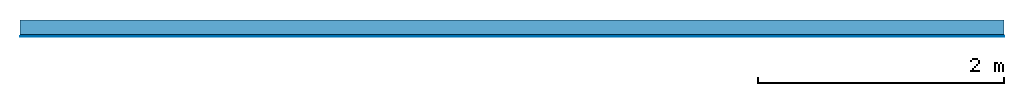
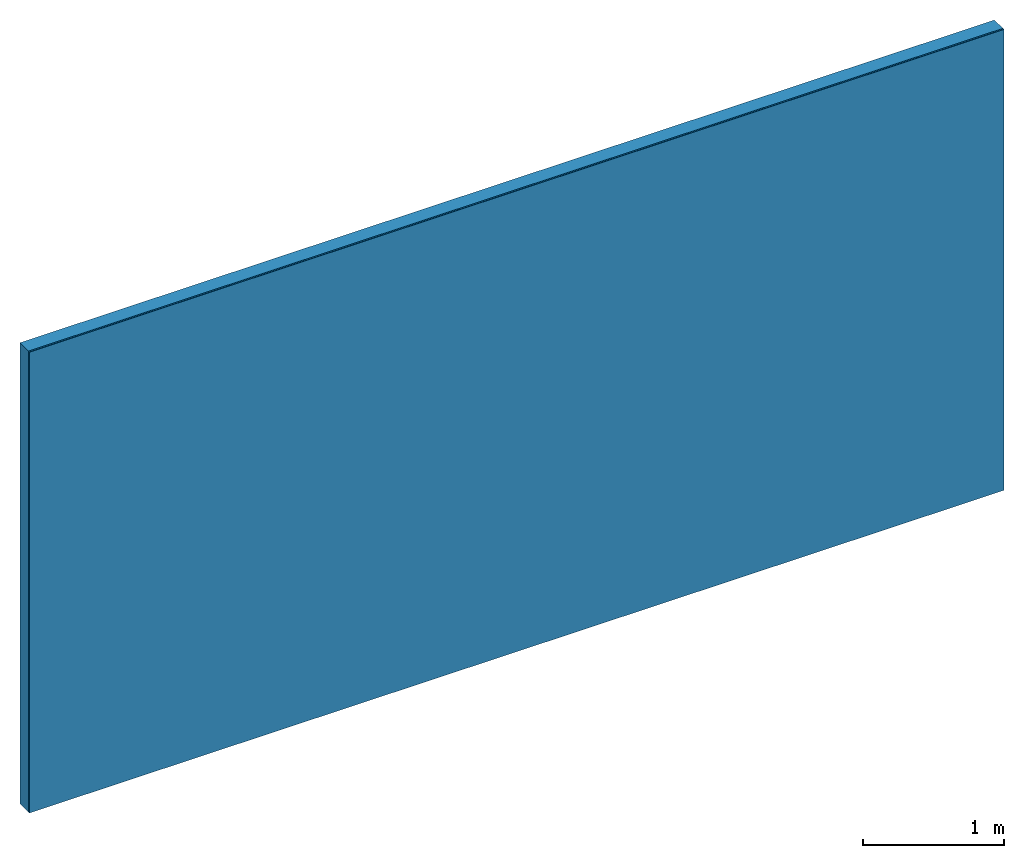
# One storey: 2 plates, 1 member, 1 element without a shape of its own.
"""IFC4 building model written with IfcOpenShell, lengths in metres."""

import ifcopenshell
import ifcopenshell.guid

model = None  # the IFC model being written
_history = None  # IfcOwnerHistory: only IFC2X3 demands one
_inside = {}  # id of a spatial element -> (the spatial element, [elements in it])
_under = {}  # id of a project, library or spatial element -> (it, [spatial elements below it])
_declared = {}  # id of a project -> (the project, [libraries it declares])
_typed = {}  # id of a type object -> (the type object, [elements of that type])
_made_of = {}  # id of a material, layer set ... -> (it, [elements and type objects made of it])


def new_model(schema):
    """Start an empty IFC model of exactly this schema.

    Asked for "IFC4X3", IfcOpenShell would pick the latest addendum, in which some entities
    have other attributes; the version numbers below select the first issue.
    IFC2X3 requires an IfcOwnerHistory on every rooted entity: one is made here for all.
    """
    global model, _history
    if schema == "IFC4X3":
        model = ifcopenshell.file(schema_version=(4, 3, 0, 0))
    else:
        model = ifcopenshell.file(schema=schema)
    _inside.clear()
    _under.clear()
    _declared.clear()
    _typed.clear()
    _made_of.clear()
    _history = None
    if model.schema == "IFC2X3":
        org = make("IfcOrganization", Name="unknown")
        user = make(
            "IfcPersonAndOrganization",
            ThePerson=make("IfcPerson", FamilyName="unknown"),
            TheOrganization=org,
        )
        app = make(
            "IfcApplication",
            ApplicationDeveloper=org,
            Version="unknown",
            ApplicationFullName="unknown",
            ApplicationIdentifier="unknown",
        )
        _history = make(
            "IfcOwnerHistory",
            OwningUser=user,
            OwningApplication=app,
            ChangeAction="ADDED",
            CreationDate=0,
        )
    return model


def make(cls, **values):
    """One entity of the class cls with the attributes given. An attribute that is None is left unset."""
    return model.create_entity(
        cls, **{name: value for name, value in values.items() if value is not None}
    )


def rooted(cls, **values):
    """An entity with a GlobalId (a new one), such as an element, a storey or a relation."""
    return make(cls, GlobalId=ifcopenshell.guid.new(), OwnerHistory=_history, **values)


def si_unit(unit_type, name, prefix=None):
    """IfcSIUnit, for example si_unit("LENGTHUNIT", "METRE", prefix="MILLI")."""
    return make("IfcSIUnit", UnitType=unit_type, Prefix=prefix, Name=name)


def derived_unit(unit_type, elements):
    """IfcDerivedUnit: a product of units, each with its exponent."""
    return make(
        "IfcDerivedUnit",
        Elements=[
            make("IfcDerivedUnitElement", Unit=unit, Exponent=power)
            for unit, power in elements
        ],
        UnitType=unit_type,
    )


def assignment(units):
    """IfcUnitAssignment: the units of a project."""
    return None if units is None else make("IfcUnitAssignment", Units=units)


def point(xyz):
    """IfcCartesianPoint."""
    return None if xyz is None else make("IfcCartesianPoint", Coordinates=xyz)


def direction(xyz):
    """IfcDirection."""
    return None if xyz is None else make("IfcDirection", DirectionRatios=xyz)


def frame(location, z_axis=None, x_axis=None):
    """IfcAxis2Placement3D, a coordinate frame: its origin and axes. An axis left out is left unset."""
    return make(
        "IfcAxis2Placement3D",
        Location=point(location),
        Axis=direction(z_axis),
        RefDirection=direction(x_axis),
    )


def frame_2d(location, x_axis=None):
    """IfcAxis2Placement2D, a coordinate frame in the plane: its origin and x axis."""
    return make(
        "IfcAxis2Placement2D", Location=point(location), RefDirection=direction(x_axis)
    )


def origin():
    """The frame at (0, 0, 0) with its axes left unset."""
    return frame((0.0, 0.0, 0.0))


def place(relative_to, where):
    """IfcLocalPlacement: puts the frame where relative to a parent placement (None: the world)."""
    return make(
        "IfcLocalPlacement", PlacementRelTo=relative_to, RelativePlacement=where
    )


def context(
    kind, dimensions, precision=None, world=None, true_north=None, identifier=None
):
    """IfcGeometricRepresentationContext, for example the 3D "Model" context."""
    return make(
        "IfcGeometricRepresentationContext",
        ContextIdentifier=identifier,
        ContextType=kind,
        CoordinateSpaceDimension=dimensions,
        Precision=precision,
        WorldCoordinateSystem=world,
        TrueNorth=true_north,
    )


def project(units=None, contexts=None):
    """IfcProject with its units and contexts."""
    return rooted(
        "IfcProject",
        Name="project",
        RepresentationContexts=contexts,
        UnitsInContext=assignment(units),
    )


def spatial(cls, under=None, at=None, **own):
    """A site, building, storey or space (cls), placed at a placement, below another one or the project."""
    s = rooted(cls, ObjectPlacement=at, **own)
    if under is not None:
        _under.setdefault(under.id(), (under, []))[1].append(s)
    return s


def profile(cls, at=None, kind="AREA", **sizes):
    """A parametric profile (cls). Its sizes go by their IFC names, for example OverallWidth=200.0."""
    return make(cls, ProfileType=kind, Position=at, **sizes)


def rectangle(**sizes):
    """IfcRectangleProfileDef."""
    return profile("IfcRectangleProfileDef", **sizes)


def extrude(swept, where, along, depth):
    """IfcExtrudedAreaSolid: the profile swept, set in the frame where, extruded along a direction by depth."""
    return make(
        "IfcExtrudedAreaSolid",
        SweptArea=swept,
        Position=where,
        ExtrudedDirection=direction(along),
        Depth=depth,
    )


def shape(context_of_items, identifier, shape_type, items):
    """IfcShapeRepresentation: the items that make up one representation, for example the "Body"."""
    return make(
        "IfcShapeRepresentation",
        ContextOfItems=context_of_items,
        RepresentationIdentifier=identifier,
        RepresentationType=shape_type,
        Items=items,
    )


def material(Name=None, Category=None):
    """IfcMaterial."""
    return make("IfcMaterial", Name=Name, Category=Category)


def layer(
    of_material, thickness, ventilated=None, Name=None, Category=None, Priority=None
):
    """IfcMaterialLayer: one layer of a wall or slab, of a material (None: an air gap)."""
    return make(
        "IfcMaterialLayer",
        Material=of_material,
        LayerThickness=thickness,
        IsVentilated=ventilated,
        Name=Name,
        Category=Category,
        Priority=Priority,
    )


def layer_set(layers, Name=None):
    """IfcMaterialLayerSet."""
    return make("IfcMaterialLayerSet", MaterialLayers=layers, LayerSetName=Name)


def made_of(thing, what):
    """Note that an element or type object is made of a material, layer set ...; save() writes the relation."""
    if what is not None:
        _made_of.setdefault(what.id(), (what, []))[1].append(thing)
    return thing


def type_object(cls, material=None, **own):
    """A type object (cls), such as IfcWallType, which elements share."""
    return made_of(rooted(cls, **own), material)


def element(
    cls,
    number,
    at=None,
    inside=None,
    cuts=None,
    type_object=None,
    material=None,
    context=None,
    identifier="Body",
    shape_type=None,
    held_by="IfcProductDefinitionShape",
    body=None,
    shapes=None,
    **own,
):
    """One element of the class cls, such as IfcWall. Its Tag is "e" and its number.

    at: its placement. inside: the storey or other place that contains it. cuts: it is an
    opening in that element (IfcRelVoidsElement). A single representation is given by context,
    identifier, shape_type and body (its items); several are given by shapes. held_by: the class
    of the entity that holds the representations. save() writes the other relations.
    """
    e = rooted(cls, Tag="e%d" % number, ObjectPlacement=at, **own)
    if body is not None:
        shapes = [shape(context, identifier, shape_type, body)]
    if shapes is not None:
        e.Representation = make(held_by, Representations=shapes)
    if inside is not None:
        _inside.setdefault(inside.id(), (inside, []))[1].append(e)
    if cuts is not None:
        rooted(
            "IfcRelVoidsElement", RelatingBuildingElement=cuts, RelatedOpeningElement=e
        )
    if type_object is not None:
        _typed.setdefault(type_object.id(), (type_object, []))[1].append(e)
    return made_of(e, material)


def aggregate(whole, parts):
    """IfcRelAggregates: a whole, such as a stair, and the parts it consists of."""
    return rooted("IfcRelAggregates", RelatingObject=whole, RelatedObjects=parts)


def save(model, path):
    """Write the relations noted so far, then the file.

    IfcRelAggregates (storeys below a building ...), IfcRelContainedInSpatialStructure (elements
    in a storey), IfcRelDefinesByType, IfcRelAssociatesMaterial and IfcRelDeclares: one each for
    every whole, place, type object, material and project.
    """
    for whole, parts in _under.values():
        aggregate(whole, parts)
    for where, things in _inside.values():
        rooted(
            "IfcRelContainedInSpatialStructure",
            RelatedElements=things,
            RelatingStructure=where,
        )
    for kind, things in _typed.values():
        rooted("IfcRelDefinesByType", RelatedObjects=things, RelatingType=kind)
    for what, things in _made_of.values():
        rooted("IfcRelAssociatesMaterial", RelatedObjects=things, RelatingMaterial=what)
    for by, libraries in _declared.values():
        rooted("IfcRelDeclares", RelatingContext=by, RelatedDefinitions=libraries)
    model.write(path)


model = new_model("IFC4")

# Units and contexts
plan_context = context("Plan", 3, precision=1e-05, world=origin(), true_north=direction((0.0, 1.0)))
model_context = context("Model", 3, precision=1e-05, world=origin(), true_north=direction((0.0, 1.0)))
ifc_project = project(units=[si_unit("LENGTHUNIT", "METRE"), derived_unit("SOUNDPRESSUREUNIT", [(si_unit("PRESSUREUNIT", "PASCAL", prefix="MICRO"), 0)]), si_unit("ENERGYUNIT", "JOULE", prefix="MEGA"), si_unit("MASSUNIT", "GRAM", prefix="KILO"), derived_unit("THERMALTRANSMITTANCEUNIT", [(si_unit("POWERUNIT", "WATT"), 1), (si_unit("AREAUNIT", "SQUARE_METRE"), -1), (si_unit("THERMODYNAMICTEMPERATUREUNIT", "KELVIN"), -1)]), derived_unit("AREADENSITYUNIT", [(si_unit("MASSUNIT", "GRAM", prefix="KILO"), 1), (si_unit("AREAUNIT", "SQUARE_METRE"), -1)]), derived_unit("USERDEFINED", [(si_unit("ENERGYUNIT", "JOULE", prefix="MEGA"), 1), (si_unit("AREAUNIT", "SQUARE_METRE"), -1)])], contexts=[plan_context, model_context])

# Site, building, storey
site = spatial("IfcSite", under=ifc_project)
building_placement = place(None, origin())
building = spatial("IfcBuilding", under=site, at=building_placement)
storey_placement = place(building_placement, origin())
storey = spatial("IfcBuildingStorey", under=building, at=storey_placement)

# Wall, member, plates
ifc_layer_1 = layer(None, 0.12, Name="Support")
ifc_material_1 = material(Name="of the art")
ifc_layer_2 = layer(ifc_material_1, 0.0, Name="Bond")
ifc_material_2 = material(Name="Plasterboard type A", Category="03.008")
ifc_layer_3 = layer(ifc_material_2, 0.0125, Name="1st layer")
ifc_material_3 = material(Category="04.001")
ifc_layer_4 = layer(ifc_material_3, 0.003, Name="Surface")
ifc_layer_set = layer_set([ifc_layer_1, ifc_layer_2, ifc_layer_3, ifc_layer_4])
wall_type = type_object("IfcWallType", Name="C0353", PredefinedType="NOTDEFINED", material=ifc_layer_set)
wall_placement = place(None, frame((0.0, 0.0, 0.0), z_axis=(0.0, -1.0, 0.0), x_axis=(1.0, 0.0, 0.0)))
wall = element("IfcWall", 1, at=wall_placement, inside=storey, type_object=wall_type, material=ifc_layer_set, Name="Wall #1")
ifc_material_4 = material(Name="Solid timber panel")
member_placement = place(wall_placement, origin())
member = element("IfcMember", 2, at=member_placement, material=ifc_material_4, Name="Support", context=plan_context, shape_type="SweptSolid", body=[
    extrude(rectangle(XDim=1.0, YDim=0.12, at=frame_2d((0.5, 0.06), x_axis=(1.0, 0.0))), frame((0.0, 4.0, 0.0), z_axis=(0.0, -1.0, 0.0), x_axis=(1.0, 0.0, 0.0)), (0.0, 0.0, 1.0), 4.0),
    extrude(rectangle(XDim=1.0, YDim=0.12, at=frame_2d((0.5, 0.06), x_axis=(1.0, 0.0))), frame((1.0, 4.0, 0.0), z_axis=(0.0, -1.0, 0.0), x_axis=(1.0, 0.0, 0.0)), (0.0, 0.0, 1.0), 4.0),
    extrude(rectangle(XDim=1.0, YDim=0.12, at=frame_2d((0.5, 0.06), x_axis=(1.0, 0.0))), frame((2.0, 4.0, 0.0), z_axis=(0.0, -1.0, 0.0), x_axis=(1.0, 0.0, 0.0)), (0.0, 0.0, 1.0), 4.0),
    extrude(rectangle(XDim=1.0, YDim=0.12, at=frame_2d((0.5, 0.06), x_axis=(1.0, 0.0))), frame((3.0, 4.0, 0.0), z_axis=(0.0, -1.0, 0.0), x_axis=(1.0, 0.0, 0.0)), (0.0, 0.0, 1.0), 4.0),
    extrude(rectangle(XDim=1.0, YDim=0.12, at=frame_2d((0.5, 0.06), x_axis=(1.0, 0.0))), frame((4.0, 4.0, 0.0), z_axis=(0.0, -1.0, 0.0), x_axis=(1.0, 0.0, 0.0)), (0.0, 0.0, 1.0), 4.0),
    extrude(rectangle(XDim=1.0, YDim=0.12, at=frame_2d((0.5, 0.06), x_axis=(1.0, 0.0))), frame((5.0, 4.0, 0.0), z_axis=(0.0, -1.0, 0.0), x_axis=(1.0, 0.0, 0.0)), (0.0, 0.0, 1.0), 4.0),
    extrude(rectangle(XDim=1.0, YDim=0.12, at=frame_2d((0.5, 0.06), x_axis=(1.0, 0.0))), frame((6.0, 4.0, 0.0), z_axis=(0.0, -1.0, 0.0), x_axis=(1.0, 0.0, 0.0)), (0.0, 0.0, 1.0), 4.0),
    extrude(rectangle(XDim=1.0, YDim=0.12, at=frame_2d((0.5, 0.06), x_axis=(1.0, 0.0))), frame((7.0, 4.0, 0.0), z_axis=(0.0, -1.0, 0.0), x_axis=(1.0, 0.0, 0.0)), (0.0, 0.0, 1.0), 4.0),
])
plate_1_placement = place(wall_placement, origin())
plate_1 = element("IfcPlate", 3, at=plate_1_placement, material=ifc_material_2, Name="1st layer", context=plan_context, shape_type="SweptSolid", body=[
    extrude(rectangle(XDim=8.0, YDim=4.0, at=frame_2d((4.0, 2.0), x_axis=(1.0, 0.0))), frame((0.0, 0.0, 0.12), z_axis=(0.0, 0.0, 1.0), x_axis=(1.0, 0.0, 0.0)), (0.0, 0.0, 1.0), 0.0125),
])
plate_2_placement = place(wall_placement, origin())
plate_2 = element("IfcPlate", 4, at=plate_2_placement, material=ifc_material_3, Name="Surface", context=plan_context, shape_type="SweptSolid", body=[
    extrude(rectangle(XDim=8.0, YDim=4.0, at=frame_2d((4.0, 2.0), x_axis=(1.0, 0.0))), frame((0.0, 0.0, 0.1325), z_axis=(0.0, 0.0, 1.0), x_axis=(1.0, 0.0, 0.0)), (0.0, 0.0, 1.0), 0.003),
])
aggregate(wall, [member, plate_1, plate_2])

save(model, "model.ifc")
